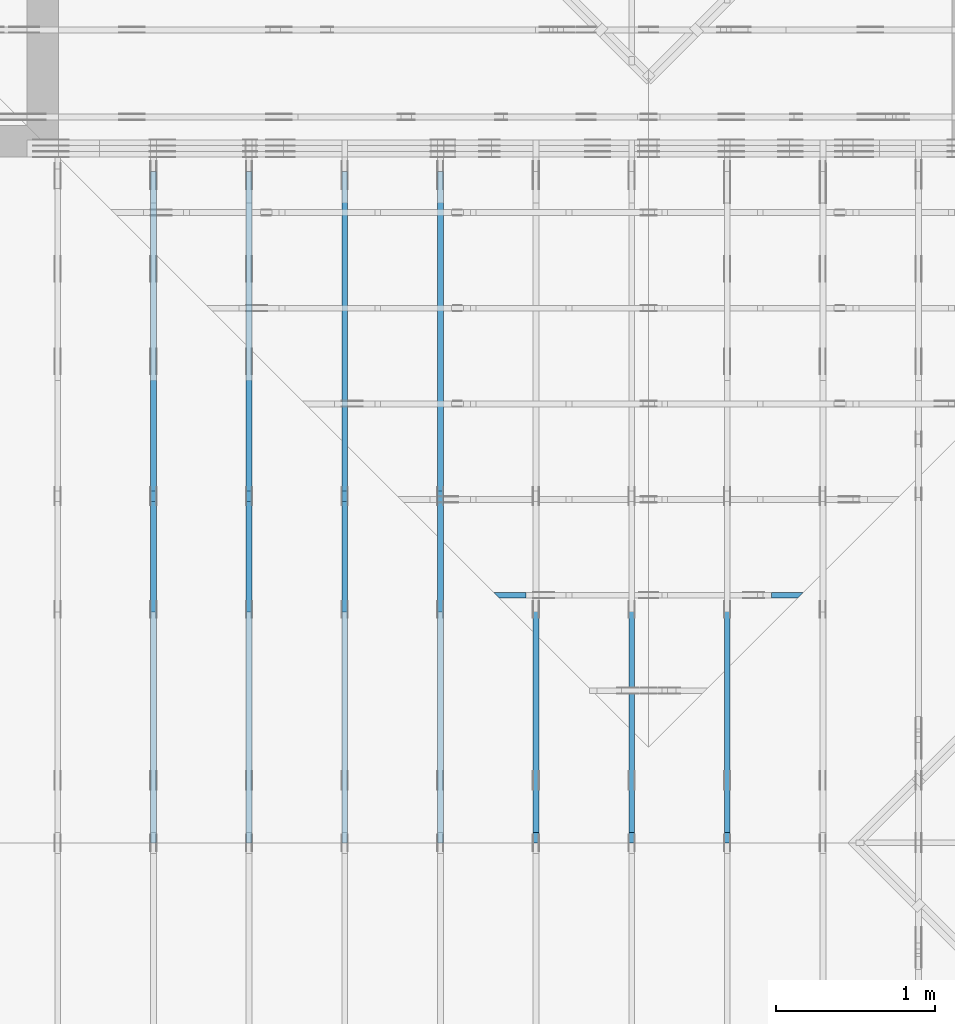
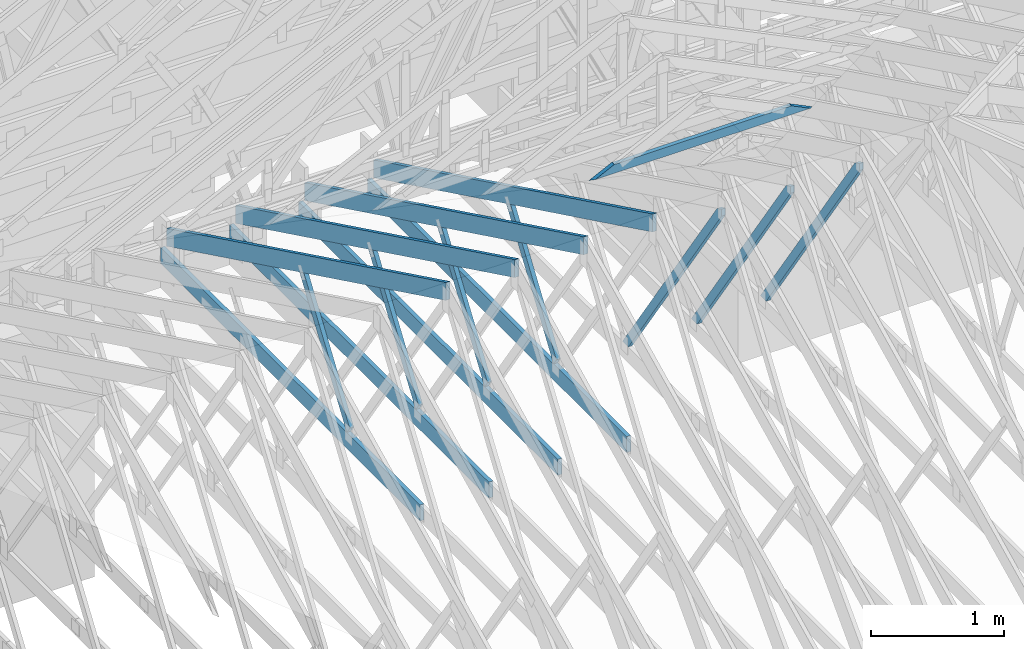
# One storey, part 18 of 159: 16 members, 8 elements without a shape of their own.
"""IFC2X3 building model written with IfcOpenShell, lengths in millimetres."""

from ifc_helpers import new_model, si_unit, frame, origin, origin_with_axes, origin_2d, place, context, project, spatial, faceted_brep, element, aggregate, save


model = new_model("IFC2X3")

# Units and contexts
model_context = context("Model", 3, precision=1e-05, world=origin())
plan_context = context("Plan", 2, precision=1e-05, world=origin_2d())
ifc_project = project(units=[si_unit("LENGTHUNIT", "METRE", prefix="MILLI"), si_unit("AREAUNIT", "SQUARE_METRE"), si_unit("VOLUMEUNIT", "CUBIC_METRE"), si_unit("SOLIDANGLEUNIT", "STERADIAN"), si_unit("PLANEANGLEUNIT", "RADIAN"), si_unit("MASSUNIT", "GRAM"), si_unit("TIMEUNIT", "SECOND"), si_unit("THERMODYNAMICTEMPERATUREUNIT", "DEGREE_CELSIUS"), si_unit("LUMINOUSINTENSITYUNIT", "LUMEN")], contexts=[model_context, plan_context])

# Site, building, storey
site_placement = place(None, origin_with_axes())
site = spatial("IfcSite", under=ifc_project, at=site_placement, CompositionType="ELEMENT")
building_placement = place(site_placement, origin_with_axes())
building = spatial("IfcBuilding", under=site, at=building_placement, Name="Plan 1", CompositionType="ELEMENT")
storey_placement = place(building_placement, origin_with_axes())
storey = spatial("IfcBuildingStorey", under=building, at=storey_placement, Name="Etasje 1", CompositionType="ELEMENT", Elevation=0.0)

# Assembly, member
assembly_1_placement = place(storey_placement, frame((15075.02226140475, -699.9989301294845, 1.1021457184401395e-15), z_axis=(-1.0, 1.836909530733566e-16, 6.123031769111886e-17), x_axis=(-1.836909530733566e-16, -1.0, 0.0)))
assembly_1 = element("IfcElementAssembly", 1, at=assembly_1_placement, inside=storey, Name="T7 (103)", AssemblyPlace="FACTORY", PredefinedType="TRUSS")
member_1_placement = place(assembly_1_placement, frame((-5230.134196319675, 2512.1392759871583, -36.0), z_axis=(0.0, 0.0, 1.0), x_axis=(-0.5642475050074617, -0.8256056886267528, 0.0)))
member_1 = element("IfcMember", 2, at=member_1_placement, Name="T7-D10", context=model_context, shape_type="Brep", body=[
    faceted_brep([(2543.5256108538483, 72.99999048793325, 36.0), (53.406771110820955, 72.99999048793325, 36.0), (0.0, 36.50009322373626, 36.0), (64.12142578860312, 0.00011835360965051223, 36.0), (2593.4163311647717, 0.00011835360965051223, 36.0), (53.406771110820955, 72.99999048793325, 6.5402271239448724e-15), (2543.5256108538483, 72.99999048793325, 3.114817624161566e-13), (2593.4163311647717, 0.00011835360965051223, 3.175914117251098e-13), (64.12142578860312, 0.00011835360965051223, 7.852350543687342e-15), (0.0, 36.50009322373626, 0.0), (3.72532881449672e-05, 36.50017519275116, 3.944304526105059e-31), (3.72532881449672e-05, 36.50017519275116, 36.0), (53.40675570041866, 73.00017519218363, 36.0), (53.40675570041866, 73.00017519218363, 7.888609052210118e-31), (64.12144158709383, 0.00017519218362238576, 7.888609052210118e-31), (64.12144158709383, 0.00017519218362593847, 36.0), (3.7253288159178055e-05, 36.500175192751165, 36.0), (3.72532881574017e-05, 36.500175192751165, -3.944304526105059e-31), (2593.4162114323694, 0.0001751921831566568, 2.916933296842317e-29), (2593.4162114323694, 0.00017519218315886108, 36.0), (64.12144158709384, 0.00017519218362346966, 36.0), (64.12144158709384, 0.00017519218362126537, 7.212035881277958e-31), (2543.52548462057, 73.00017519218363, -8.473528143218631e-30), (2543.52548462057, 73.00017519218363, 36.0), (2593.41621143237, 0.00017519218386041757, 36.0), (2593.41621143237, 0.00017519218386041757, -9.018458054926462e-30), (53.40675570041867, 73.00017519218363, 0.0), (53.40675570041867, 73.00017519218363, 36.0), (2543.52548462057, 73.00017519218348, 36.0), (2543.52548462057, 73.00017519218348, -9.466330862652142e-30)], [[[0, 1, 2, 3, 4]], [[5, 6, 7, 8, 9]], [[10, 11, 12, 13]], [[14, 15, 16, 17]], [[18, 19, 20, 21]], [[22, 23, 24, 25]], [[26, 27, 28, 29]]]),
])
aggregate(assembly_1, [member_1])

assembly_2_placement = place(storey_placement, frame((14475.022261404752, -699.9989301294836, 1.1021457184401395e-15), z_axis=(-1.0, 1.836909530733566e-16, 6.123031769111886e-17), x_axis=(-1.836909530733566e-16, -1.0, 0.0)))
assembly_2 = element("IfcElementAssembly", 3, at=assembly_2_placement, inside=storey, Name="T10 (102)", AssemblyPlace="FACTORY", PredefinedType="TRUSS")
member_2_placement = place(assembly_2_placement, frame((-5230.134196319675, 2512.1392759871583, -36.0), z_axis=(0.0, 0.0, 1.0), x_axis=(-0.5642475050074617, -0.8256056886267528, 0.0)))
member_2 = element("IfcMember", 4, at=member_2_placement, Name="T10-D10", context=model_context, shape_type="Brep", body=[
    faceted_brep([(2543.5256108538483, 72.99999048793325, 36.0), (53.406771110820955, 72.99999048793325, 36.0), (0.0, 36.50009322373626, 36.0), (64.12142578860312, 0.00011835360965051223, 36.0), (2593.4163311647717, 0.00011835360965051223, 36.0), (53.406771110820955, 72.99999048793325, 6.5402271239448724e-15), (2543.5256108538483, 72.99999048793325, 3.114817624161566e-13), (2593.4163311647717, 0.00011835360965051223, 3.175914117251098e-13), (64.12142578860312, 0.00011835360965051223, 7.852350543687342e-15), (0.0, 36.50009322373626, 0.0), (3.72532881449672e-05, 36.50017519275116, 3.944304526105059e-31), (3.72532881449672e-05, 36.50017519275116, 36.0), (53.40675570041866, 73.00017519218363, 36.0), (53.40675570041866, 73.00017519218363, 7.888609052210118e-31), (64.12144158709383, 0.00017519218362238576, 7.888609052210118e-31), (64.12144158709383, 0.00017519218362593847, 36.0), (3.7253288159178055e-05, 36.500175192751165, 36.0), (3.72532881574017e-05, 36.500175192751165, -3.944304526105059e-31), (2593.4162114323694, 0.0001751921831566568, 2.916933296842317e-29), (2593.4162114323694, 0.00017519218315886108, 36.0), (64.12144158709384, 0.00017519218362346966, 36.0), (64.12144158709384, 0.00017519218362126537, 7.212035881277958e-31), (2543.52548462057, 73.00017519218363, -8.473528143218631e-30), (2543.52548462057, 73.00017519218363, 36.0), (2593.41621143237, 0.00017519218386041757, 36.0), (2593.41621143237, 0.00017519218386041757, -9.018458054926462e-30), (53.40675570041867, 73.00017519218363, 0.0), (53.40675570041867, 73.00017519218363, 36.0), (2543.52548462057, 73.00017519218348, 36.0), (2543.52548462057, 73.00017519218348, -9.466330862652142e-30)], [[[0, 1, 2, 3, 4]], [[5, 6, 7, 8, 9]], [[10, 11, 12, 13]], [[14, 15, 16, 17]], [[18, 19, 20, 21]], [[22, 23, 24, 25]], [[26, 27, 28, 29]]]),
])
aggregate(assembly_2, [member_2])

assembly_3_placement = place(storey_placement, frame((13875.022261404752, -699.9989301294836, 1.1021457184401395e-15), z_axis=(-1.0, 1.836909530733566e-16, 6.123031769111886e-17), x_axis=(-1.836909530733566e-16, -1.0, 0.0)))
assembly_3 = element("IfcElementAssembly", 5, at=assembly_3_placement, inside=storey, Name="T6 (101)", AssemblyPlace="FACTORY", PredefinedType="TRUSS")
member_3_placement = place(assembly_3_placement, frame((-5230.134196319675, 2512.1392759871583, -36.0), z_axis=(0.0, 0.0, 1.0), x_axis=(-0.5642475050074617, -0.8256056886267528, 0.0)))
member_3 = element("IfcMember", 6, at=member_3_placement, Name="T6-D10", context=model_context, shape_type="Brep", body=[
    faceted_brep([(2543.5256108538483, 72.99999048793325, 36.0), (53.406771110820955, 72.99999048793325, 36.0), (0.0, 36.50009322373626, 36.0), (64.12142578860312, 0.00011835360965051223, 36.0), (2593.4163311647717, 0.00011835360965051223, 36.0), (53.406771110820955, 72.99999048793325, 6.5402271239448724e-15), (2543.5256108538483, 72.99999048793325, 3.114817624161566e-13), (2593.4163311647717, 0.00011835360965051223, 3.175914117251098e-13), (64.12142578860312, 0.00011835360965051223, 7.852350543687342e-15), (0.0, 36.50009322373626, 0.0), (3.72532881449672e-05, 36.50017519275116, 3.944304526105059e-31), (3.72532881449672e-05, 36.50017519275116, 36.0), (53.40675570041866, 73.00017519218363, 36.0), (53.40675570041866, 73.00017519218363, 7.888609052210118e-31), (64.12144158709383, 0.00017519218362238576, 7.888609052210118e-31), (64.12144158709383, 0.00017519218362593847, 36.0), (3.7253288159178055e-05, 36.500175192751165, 36.0), (3.72532881574017e-05, 36.500175192751165, -3.944304526105059e-31), (2593.4162114323694, 0.0001751921831566568, 2.916933296842317e-29), (2593.4162114323694, 0.00017519218315886108, 36.0), (64.12144158709384, 0.00017519218362346966, 36.0), (64.12144158709384, 0.00017519218362126537, 7.212035881277958e-31), (2543.52548462057, 73.00017519218363, -8.473528143218631e-30), (2543.52548462057, 73.00017519218363, 36.0), (2593.41621143237, 0.00017519218386041757, 36.0), (2593.41621143237, 0.00017519218386041757, -9.018458054926462e-30), (53.40675570041867, 73.00017519218363, 0.0), (53.40675570041867, 73.00017519218363, 36.0), (2543.52548462057, 73.00017519218348, 36.0), (2543.52548462057, 73.00017519218348, -9.466330862652142e-30)], [[[0, 1, 2, 3, 4]], [[5, 6, 7, 8, 9]], [[10, 11, 12, 13]], [[14, 15, 16, 17]], [[18, 19, 20, 21]], [[22, 23, 24, 25]], [[26, 27, 28, 29]]]),
])
aggregate(assembly_3, [member_3])

# Assembly, members
assembly_4_placement = place(storey_placement, frame((13275.022261404752, -699.9989301294836, 1.1021457184401395e-15), z_axis=(-1.0, 1.836909530733566e-16, 6.123031769111886e-17), x_axis=(-1.836909530733566e-16, -1.0, 0.0)))
assembly_4 = element("IfcElementAssembly", 7, at=assembly_4_placement, inside=storey, Name="T6 (100)", AssemblyPlace="FACTORY", PredefinedType="TRUSS")
member_4_placement = place(assembly_4_placement, frame((-9411.999005287185, 437.2146234308699, -36.00000000000001), z_axis=(0.0, 0.0, 1.0), x_axis=(0.8987940462991673, 0.43837114678907735, 0.0)))
member_4 = element("IfcMember", 8, at=member_4_placement, Name="T6-O11", context=model_context, shape_type="Brep", body=[
    faceted_brep([(4758.463277584195, 148.00009154954296, 36.0), (72.18442876594781, 148.00009154954296, 36.0), (0.0, 4.140399232710479e-05, 36.0), (4686.278875574299, 4.140399232710479e-05, 36.0), (72.18442876594781, 148.00009154954296, 8.839751011381847e-15), (4758.463277584195, 148.00009154954296, 5.82724436416006e-13), (4686.278875574299, 4.140399232710479e-05, 5.738846886811872e-13), (0.0, 4.140399232710479e-05, 0.0), (8.360351420234293e-05, 5.140324472498181e-15, 7.179836740020234e-31), (8.360351420432413e-05, 4.174029286270475e-15, 36.0), (72.18450667705471, 147.99999999603824, 36.0), (72.18450667705471, 147.99999999603824, 1.530729119798975e-30), (4686.27888374885, 4.514103814251943e-05, -1.8242490005659002e-29), (4686.27888374885, 4.514103814472372e-05, 36.0), (8.360351421288216e-05, 2.204296752011599e-15, 36.0), (8.360351421288216e-05, 5.315131319929112e-21, -3.254471682622608e-37), (4758.463306857064, 148.00004514198963, 1.58299098763632e-28), (4758.463306857064, 148.00004514198963, 36.0), (4686.2788837488515, 4.5141036935092416e-05, 36.0), (4686.2788837488515, 4.5141036935092416e-05, 1.0730458735393999e-28), (72.18450667705474, 147.99999999603824, 0.0), (72.18450667705474, 147.99999999603824, 36.0), (4758.463306857063, 148.00004514199048, 36.0), (4758.463306857063, 148.00004514199048, -2.8398992587956425e-29)], [[[0, 1, 2, 3]], [[4, 5, 6, 7]], [[8, 9, 10, 11]], [[12, 13, 14, 15]], [[16, 17, 18, 19]], [[20, 21, 22, 23]]]),
])
member_5_placement = place(assembly_4_placement, frame((-5591.18115234375, 371.0, -36.0), z_axis=(0.0, 0.0, 1.0), x_axis=(-1.0, 1.2246063538223773e-16, 0.0)))
member_5 = element("IfcMember", 9, at=member_5_placement, Name="T6-U39", context=model_context, shape_type="Brep", body=[
    faceted_brep([(3910.81787109375, 148.00000000000048, 36.0), (0.0, 148.00000000000048, 36.0), (0.0, 0.0, 36.0), (3910.81787109375, 0.0, 36.0), (0.0, 148.00000000000048, 0.0), (3910.81787109375, 148.00000000000048, 4.789212413583509e-13), (3910.81787109375, 0.0, 4.789212413583509e-13), (0.0, 0.0, 0.0), (0.0001433398574590683, 3.979039320256561e-13, 0.0), (0.0001433398574612726, 3.979039320256561e-13, 36.0), (0.00014333985747939676, 148.00000000000037, 36.0), (0.00014333985747719247, 148.00000000000037, -1.1097494219785373e-30), (3910.817777776101, -3.204779149536956e-13, 4.746728930957506e-29), (3910.817777776101, -3.182736235168153e-13, 36.0), (0.0001433398574590683, 4.001081950488681e-13, 36.0), (0.0001433398574590683, 3.9790390361198783e-13, 1.73977793531565e-36), (3910.817777776101, 148.00000000000048, 0.0), (3910.817777776101, 148.00000000000048, 36.0), (3910.817777776101, 4.547473508864641e-13, 36.0), (3910.817777776101, 4.547473508864641e-13, 0.0), (0.0001433398574590683, 148.00000000000037, 0.0), (0.0001433398574590683, 148.00000000000037, 36.0), (3910.817777776101, 148.0000000000001, 36.0), (3910.817777776101, 148.00000000000014, -2.208810534618833e-29)], [[[0, 1, 2, 3]], [[4, 5, 6, 7]], [[8, 9, 10, 11]], [[12, 13, 14, 15]], [[16, 17, 18, 19]], [[20, 21, 22, 23]]]),
])
member_6_placement = place(assembly_4_placement, frame((-7407.03695472166, 1415.0999762480442, -36.0), z_axis=(0.0, 0.0, 1.0), x_axis=(0.5642475050064201, -0.8256056886274645, 0.0)))
member_6 = element("IfcMember", 10, at=member_6_placement, Name="T6-D42", context=model_context, shape_type="Brep", body=[
    faceted_brep([(1236.1859046255386, 72.99999679664234, 36.0), (10.714742691100582, 72.99999679664234, 36.0), (8.80134111866937e-05, 0.0003439493775658775, 36.0), (1264.647265190018, 0.0003439493775658775, 36.0), (10.714742691100582, 72.99999679664234, 1.312134197909365e-15), (1236.1859046255386, 72.99999679664234, 1.5138411133100978e-13), (1264.647265190018, 0.0003439493775658775, 1.548695076295789e-13), (8.80134111866937e-05, 0.0003439493775658775, 1.077817825608066e-20), (1.2441219929271163e-16, 0.00017519218454252033, -7.699393958337917e-33), (2.305335691224139e-15, 0.00017519218454220022, 36.0), (10.714685884795475, 73.00017519218454, 36.0), (10.714685884795474, 73.00017519218454, -2.956283656724794e-32), (1264.6473849224226, 0.00017519218655669935, 4.373824669985916e-29), (1264.6473849224226, 0.00017519218655890365, 36.0), (-3.510681399126273e-30, 0.0001751921845447429, 36.0), (0.0, 0.0001751921845425386, 0.0), (1236.1860298802894, 73.00017519218727, -1.3795914725131465e-29), (1236.1860298802894, 73.00017519218727, 36.0), (1264.6473849224226, 0.0001751921872710227, 36.0), (1264.6473849224226, 0.0001751921872710227, -1.4037355718167356e-29), (10.714685884795474, 73.00017519218454, 0.0), (10.714685884795474, 73.00017519218453, 36.0), (1236.1860298802894, 73.00017519218719, 36.0), (1236.1860298802894, 73.00017519218719, -5.5220263365470826e-30)], [[[0, 1, 2, 3]], [[4, 5, 6, 7]], [[8, 9, 10, 11]], [[12, 13, 14, 15]], [[16, 17, 18, 19]], [[20, 21, 22, 23]]]),
])
aggregate(assembly_4, [member_4, member_5, member_6])

assembly_5_placement = place(storey_placement, frame((12675.022261404752, -699.9989301294854, 4.558494966049043e-13), z_axis=(-1.0, 1.836909530733566e-16, 6.123031769111886e-17), x_axis=(-1.836909530733566e-16, -1.0, 0.0)))
assembly_5 = element("IfcElementAssembly", 11, at=assembly_5_placement, inside=storey, Name="T6 (99)", AssemblyPlace="FACTORY", PredefinedType="TRUSS")
member_7_placement = place(assembly_5_placement, frame((-9411.999005287185, 437.2146234308699, -36.00000000000001), z_axis=(0.0, 0.0, 1.0), x_axis=(0.8987940462991673, 0.43837114678907735, 0.0)))
member_7 = element("IfcMember", 12, at=member_7_placement, Name="T6-O11", context=model_context, shape_type="Brep", body=[
    faceted_brep([(4758.463277584195, 148.00009154954296, 36.0), (72.18442876594781, 148.00009154954296, 36.0), (0.0, 4.140399232710479e-05, 36.0), (4686.278875574299, 4.140399232710479e-05, 36.0), (72.18442876594781, 148.00009154954296, 8.839751011381847e-15), (4758.463277584195, 148.00009154954296, 5.82724436416006e-13), (4686.278875574299, 4.140399232710479e-05, 5.738846886811872e-13), (0.0, 4.140399232710479e-05, 0.0), (8.360351420234293e-05, 5.140324472498181e-15, 7.179836740020234e-31), (8.360351420432413e-05, 4.174029286270475e-15, 36.0), (72.18450667705471, 147.99999999603824, 36.0), (72.18450667705471, 147.99999999603824, 1.530729119798975e-30), (4686.27888374885, 4.514103814251943e-05, -1.8242490005659002e-29), (4686.27888374885, 4.514103814472372e-05, 36.0), (8.360351421288216e-05, 2.204296752011599e-15, 36.0), (8.360351421288216e-05, 5.315131319929112e-21, -3.254471682622608e-37), (4758.463306857064, 148.00004514198963, 1.58299098763632e-28), (4758.463306857064, 148.00004514198963, 36.0), (4686.2788837488515, 4.5141036935092416e-05, 36.0), (4686.2788837488515, 4.5141036935092416e-05, 1.0730458735393999e-28), (72.18450667705474, 147.99999999603824, 0.0), (72.18450667705474, 147.99999999603824, 36.0), (4758.463306857063, 148.00004514199048, 36.0), (4758.463306857063, 148.00004514199048, -2.8398992587956425e-29)], [[[0, 1, 2, 3]], [[4, 5, 6, 7]], [[8, 9, 10, 11]], [[12, 13, 14, 15]], [[16, 17, 18, 19]], [[20, 21, 22, 23]]]),
])
member_8_placement = place(assembly_5_placement, frame((-5591.18115234375, 371.0, -36.0), z_axis=(0.0, 0.0, 1.0), x_axis=(-1.0, 1.2246063538223773e-16, 0.0)))
member_8 = element("IfcMember", 13, at=member_8_placement, Name="T6-U39", context=model_context, shape_type="Brep", body=[
    faceted_brep([(3910.81787109375, 148.00000000000048, 36.0), (0.0, 148.00000000000048, 36.0), (0.0, 0.0, 36.0), (3910.81787109375, 0.0, 36.0), (0.0, 148.00000000000048, 0.0), (3910.81787109375, 148.00000000000048, 4.789212413583509e-13), (3910.81787109375, 0.0, 4.789212413583509e-13), (0.0, 0.0, 0.0), (0.0001433398574590683, 3.979039320256561e-13, 0.0), (0.0001433398574612726, 3.979039320256561e-13, 36.0), (0.00014333985747939676, 148.00000000000037, 36.0), (0.00014333985747719247, 148.00000000000037, -1.1097494219785373e-30), (3910.817777776101, -3.204779149536956e-13, 4.746728930957506e-29), (3910.817777776101, -3.182736235168153e-13, 36.0), (0.0001433398574590683, 4.001081950488681e-13, 36.0), (0.0001433398574590683, 3.9790390361198783e-13, 1.73977793531565e-36), (3910.817777776101, 148.00000000000048, 0.0), (3910.817777776101, 148.00000000000048, 36.0), (3910.817777776101, 4.547473508864641e-13, 36.0), (3910.817777776101, 4.547473508864641e-13, 0.0), (0.0001433398574590683, 148.00000000000037, 0.0), (0.0001433398574590683, 148.00000000000037, 36.0), (3910.817777776101, 148.0000000000001, 36.0), (3910.817777776101, 148.00000000000014, -2.208810534618833e-29)], [[[0, 1, 2, 3]], [[4, 5, 6, 7]], [[8, 9, 10, 11]], [[12, 13, 14, 15]], [[16, 17, 18, 19]], [[20, 21, 22, 23]]]),
])
member_9_placement = place(assembly_5_placement, frame((-7407.03695472166, 1415.0999762480442, -36.0), z_axis=(0.0, 0.0, 1.0), x_axis=(0.5642475050064201, -0.8256056886274645, 0.0)))
member_9 = element("IfcMember", 14, at=member_9_placement, Name="T6-D42", context=model_context, shape_type="Brep", body=[
    faceted_brep([(1236.1859046255386, 72.99999679664234, 36.0), (10.714742691100582, 72.99999679664234, 36.0), (8.80134111866937e-05, 0.0003439493775658775, 36.0), (1264.647265190018, 0.0003439493775658775, 36.0), (10.714742691100582, 72.99999679664234, 1.312134197909365e-15), (1236.1859046255386, 72.99999679664234, 1.5138411133100978e-13), (1264.647265190018, 0.0003439493775658775, 1.548695076295789e-13), (8.80134111866937e-05, 0.0003439493775658775, 1.077817825608066e-20), (1.2441219929271163e-16, 0.00017519218454252033, -7.699393958337917e-33), (2.305335691224139e-15, 0.00017519218454220022, 36.0), (10.714685884795475, 73.00017519218454, 36.0), (10.714685884795474, 73.00017519218454, -2.956283656724794e-32), (1264.6473849224226, 0.00017519218655669935, 4.373824669985916e-29), (1264.6473849224226, 0.00017519218655890365, 36.0), (-3.510681399126273e-30, 0.0001751921845447429, 36.0), (0.0, 0.0001751921845425386, 0.0), (1236.1860298802894, 73.00017519218727, -1.3795914725131465e-29), (1236.1860298802894, 73.00017519218727, 36.0), (1264.6473849224226, 0.0001751921872710227, 36.0), (1264.6473849224226, 0.0001751921872710227, -1.4037355718167356e-29), (10.714685884795474, 73.00017519218454, 0.0), (10.714685884795474, 73.00017519218453, 36.0), (1236.1860298802894, 73.00017519218719, 36.0), (1236.1860298802894, 73.00017519218719, -5.5220263365470826e-30)], [[[0, 1, 2, 3]], [[4, 5, 6, 7]], [[8, 9, 10, 11]], [[12, 13, 14, 15]], [[16, 17, 18, 19]], [[20, 21, 22, 23]]]),
])
aggregate(assembly_5, [member_7, member_8, member_9])

assembly_6_placement = place(storey_placement, frame((12075.022261404752, -699.9989301294854, 4.558494966049043e-13), z_axis=(-1.0, 1.836909530733566e-16, 6.123031769111886e-17), x_axis=(-1.836909530733566e-16, -1.0, 0.0)))
assembly_6 = element("IfcElementAssembly", 15, at=assembly_6_placement, inside=storey, Name="T5 (98)", AssemblyPlace="FACTORY", PredefinedType="TRUSS")
member_10_placement = place(assembly_6_placement, frame((-9411.999005287185, 437.2146234308699, -36.00000000000001), z_axis=(0.0, 0.0, 1.0), x_axis=(0.8987940462991673, 0.43837114678907735, 0.0)))
member_10 = element("IfcMember", 16, at=member_10_placement, Name="T5-O11", context=model_context, shape_type="Brep", body=[
    faceted_brep([(4758.463277584195, 148.00009154954296, 36.0), (72.18442876594781, 148.00009154954296, 36.0), (0.0, 4.140399232710479e-05, 36.0), (4686.278875574299, 4.140399232710479e-05, 36.0), (72.18442876594781, 148.00009154954296, 8.839751011381847e-15), (4758.463277584195, 148.00009154954296, 5.82724436416006e-13), (4686.278875574299, 4.140399232710479e-05, 5.738846886811872e-13), (0.0, 4.140399232710479e-05, 0.0), (8.360351420234293e-05, 5.140324472498181e-15, 7.179836740020234e-31), (8.360351420432413e-05, 4.174029286270475e-15, 36.0), (72.18450667705471, 147.99999999603824, 36.0), (72.18450667705471, 147.99999999603824, 1.530729119798975e-30), (4686.27888374885, 4.514103814251943e-05, -1.8242490005659002e-29), (4686.27888374885, 4.514103814472372e-05, 36.0), (8.360351421288216e-05, 2.204296752011599e-15, 36.0), (8.360351421288216e-05, 5.315131319929112e-21, -3.254471682622608e-37), (4758.463306857064, 148.00004514198963, 1.58299098763632e-28), (4758.463306857064, 148.00004514198963, 36.0), (4686.2788837488515, 4.5141036935092416e-05, 36.0), (4686.2788837488515, 4.5141036935092416e-05, 1.0730458735393999e-28), (72.18450667705474, 147.99999999603824, 0.0), (72.18450667705474, 147.99999999603824, 36.0), (4758.463306857063, 148.00004514199048, 36.0), (4758.463306857063, 148.00004514199048, -2.8398992587956425e-29)], [[[0, 1, 2, 3]], [[4, 5, 6, 7]], [[8, 9, 10, 11]], [[12, 13, 14, 15]], [[16, 17, 18, 19]], [[20, 21, 22, 23]]]),
])
member_11_placement = place(assembly_6_placement, frame((-5591.18115234375, 371.0, -36.0), z_axis=(0.0, 0.0, 1.0), x_axis=(-1.0, 1.2246063538223773e-16, 0.0)))
member_11 = element("IfcMember", 17, at=member_11_placement, Name="T5-U39", context=model_context, shape_type="Brep", body=[
    faceted_brep([(3910.81787109375, 148.00000000000048, 36.0), (0.0, 148.00000000000048, 36.0), (0.0, 0.0, 36.0), (3910.81787109375, 0.0, 36.0), (0.0, 148.00000000000048, 0.0), (3910.81787109375, 148.00000000000048, 4.789212413583509e-13), (3910.81787109375, 0.0, 4.789212413583509e-13), (0.0, 0.0, 0.0), (0.0001433398574590683, 3.979039320256561e-13, 0.0), (0.0001433398574612726, 3.979039320256561e-13, 36.0), (0.00014333985747939676, 148.00000000000037, 36.0), (0.00014333985747719247, 148.00000000000037, -1.1097494219785373e-30), (3910.817777776101, -3.204779149536956e-13, 4.746728930957506e-29), (3910.817777776101, -3.182736235168153e-13, 36.0), (0.0001433398574590683, 4.001081950488681e-13, 36.0), (0.0001433398574590683, 3.9790390361198783e-13, 1.73977793531565e-36), (3910.817777776101, 148.00000000000048, 0.0), (3910.817777776101, 148.00000000000048, 36.0), (3910.817777776101, 4.547473508864641e-13, 36.0), (3910.817777776101, 4.547473508864641e-13, 0.0), (0.0001433398574590683, 148.00000000000037, 0.0), (0.0001433398574590683, 148.00000000000037, 36.0), (3910.817777776101, 148.0000000000001, 36.0), (3910.817777776101, 148.00000000000014, -2.208810534618833e-29)], [[[0, 1, 2, 3]], [[4, 5, 6, 7]], [[8, 9, 10, 11]], [[12, 13, 14, 15]], [[16, 17, 18, 19]], [[20, 21, 22, 23]]]),
])
member_12_placement = place(assembly_6_placement, frame((-7407.03695472166, 1415.0999762480442, -36.0), z_axis=(0.0, 0.0, 1.0), x_axis=(0.5642475050064201, -0.8256056886274645, 0.0)))
member_12 = element("IfcMember", 18, at=member_12_placement, Name="T5-D42", context=model_context, shape_type="Brep", body=[
    faceted_brep([(1236.1859046255386, 72.99999679664234, 36.0), (10.714742691100582, 72.99999679664234, 36.0), (8.80134111866937e-05, 0.0003439493775658775, 36.0), (1264.647265190018, 0.0003439493775658775, 36.0), (10.714742691100582, 72.99999679664234, 1.312134197909365e-15), (1236.1859046255386, 72.99999679664234, 1.5138411133100978e-13), (1264.647265190018, 0.0003439493775658775, 1.548695076295789e-13), (8.80134111866937e-05, 0.0003439493775658775, 1.077817825608066e-20), (1.2441219929271163e-16, 0.00017519218454252033, -7.699393958337917e-33), (2.305335691224139e-15, 0.00017519218454220022, 36.0), (10.714685884795475, 73.00017519218454, 36.0), (10.714685884795474, 73.00017519218454, -2.956283656724794e-32), (1264.6473849224226, 0.00017519218655669935, 4.373824669985916e-29), (1264.6473849224226, 0.00017519218655890365, 36.0), (-3.510681399126273e-30, 0.0001751921845447429, 36.0), (0.0, 0.0001751921845425386, 0.0), (1236.1860298802894, 73.00017519218727, -1.3795914725131465e-29), (1236.1860298802894, 73.00017519218727, 36.0), (1264.6473849224226, 0.0001751921872710227, 36.0), (1264.6473849224226, 0.0001751921872710227, -1.4037355718167356e-29), (10.714685884795474, 73.00017519218454, 0.0), (10.714685884795474, 73.00017519218453, 36.0), (1236.1860298802894, 73.00017519218719, 36.0), (1236.1860298802894, 73.00017519218719, -5.5220263365470826e-30)], [[[0, 1, 2, 3]], [[4, 5, 6, 7]], [[8, 9, 10, 11]], [[12, 13, 14, 15]], [[16, 17, 18, 19]], [[20, 21, 22, 23]]]),
])
aggregate(assembly_6, [member_10, member_11, member_12])

assembly_7_placement = place(storey_placement, frame((11475.022261404752, -699.9989301294845, 1.1021457184401395e-15), z_axis=(-1.0, 1.836909530733566e-16, 6.123031769111886e-17), x_axis=(-1.836909530733566e-16, -1.0, 0.0)))
assembly_7 = element("IfcElementAssembly", 19, at=assembly_7_placement, inside=storey, Name="T5 (97)", AssemblyPlace="FACTORY", PredefinedType="TRUSS")
member_13_placement = place(assembly_7_placement, frame((-9411.999005287185, 437.2146234308699, -36.00000000000001), z_axis=(0.0, 0.0, 1.0), x_axis=(0.8987940462991673, 0.43837114678907735, 0.0)))
member_13 = element("IfcMember", 20, at=member_13_placement, Name="T5-O11", context=model_context, shape_type="Brep", body=[
    faceted_brep([(4758.463277584195, 148.00009154954296, 36.0), (72.18442876594781, 148.00009154954296, 36.0), (0.0, 4.140399232710479e-05, 36.0), (4686.278875574299, 4.140399232710479e-05, 36.0), (72.18442876594781, 148.00009154954296, 8.839751011381847e-15), (4758.463277584195, 148.00009154954296, 5.82724436416006e-13), (4686.278875574299, 4.140399232710479e-05, 5.738846886811872e-13), (0.0, 4.140399232710479e-05, 0.0), (8.360351420234293e-05, 5.140324472498181e-15, 7.179836740020234e-31), (8.360351420432413e-05, 4.174029286270475e-15, 36.0), (72.18450667705471, 147.99999999603824, 36.0), (72.18450667705471, 147.99999999603824, 1.530729119798975e-30), (4686.27888374885, 4.514103814251943e-05, -1.8242490005659002e-29), (4686.27888374885, 4.514103814472372e-05, 36.0), (8.360351421288216e-05, 2.204296752011599e-15, 36.0), (8.360351421288216e-05, 5.315131319929112e-21, -3.254471682622608e-37), (4758.463306857064, 148.00004514198963, 1.58299098763632e-28), (4758.463306857064, 148.00004514198963, 36.0), (4686.2788837488515, 4.5141036935092416e-05, 36.0), (4686.2788837488515, 4.5141036935092416e-05, 1.0730458735393999e-28), (72.18450667705474, 147.99999999603824, 0.0), (72.18450667705474, 147.99999999603824, 36.0), (4758.463306857063, 148.00004514199048, 36.0), (4758.463306857063, 148.00004514199048, -2.8398992587956425e-29)], [[[0, 1, 2, 3]], [[4, 5, 6, 7]], [[8, 9, 10, 11]], [[12, 13, 14, 15]], [[16, 17, 18, 19]], [[20, 21, 22, 23]]]),
])
member_14_placement = place(assembly_7_placement, frame((-5591.18115234375, 371.0, -36.0), z_axis=(0.0, 0.0, 1.0), x_axis=(-1.0, 1.2246063538223773e-16, 0.0)))
member_14 = element("IfcMember", 21, at=member_14_placement, Name="T5-U39", context=model_context, shape_type="Brep", body=[
    faceted_brep([(3910.81787109375, 148.00000000000048, 36.0), (0.0, 148.00000000000048, 36.0), (0.0, 0.0, 36.0), (3910.81787109375, 0.0, 36.0), (0.0, 148.00000000000048, 0.0), (3910.81787109375, 148.00000000000048, 4.789212413583509e-13), (3910.81787109375, 0.0, 4.789212413583509e-13), (0.0, 0.0, 0.0), (0.0001433398574590683, 3.979039320256561e-13, 0.0), (0.0001433398574612726, 3.979039320256561e-13, 36.0), (0.00014333985747939676, 148.00000000000037, 36.0), (0.00014333985747719247, 148.00000000000037, -1.1097494219785373e-30), (3910.817777776101, -3.204779149536956e-13, 4.746728930957506e-29), (3910.817777776101, -3.182736235168153e-13, 36.0), (0.0001433398574590683, 4.001081950488681e-13, 36.0), (0.0001433398574590683, 3.9790390361198783e-13, 1.73977793531565e-36), (3910.817777776101, 148.00000000000048, 0.0), (3910.817777776101, 148.00000000000048, 36.0), (3910.817777776101, 4.547473508864641e-13, 36.0), (3910.817777776101, 4.547473508864641e-13, 0.0), (0.0001433398574590683, 148.00000000000037, 0.0), (0.0001433398574590683, 148.00000000000037, 36.0), (3910.817777776101, 148.0000000000001, 36.0), (3910.817777776101, 148.00000000000014, -2.208810534618833e-29)], [[[0, 1, 2, 3]], [[4, 5, 6, 7]], [[8, 9, 10, 11]], [[12, 13, 14, 15]], [[16, 17, 18, 19]], [[20, 21, 22, 23]]]),
])
member_15_placement = place(assembly_7_placement, frame((-7407.03695472166, 1415.0999762480442, -36.0), z_axis=(0.0, 0.0, 1.0), x_axis=(0.5642475050064201, -0.8256056886274645, 0.0)))
member_15 = element("IfcMember", 22, at=member_15_placement, Name="T5-D42", context=model_context, shape_type="Brep", body=[
    faceted_brep([(1236.1859046255386, 72.99999679664234, 36.0), (10.714742691100582, 72.99999679664234, 36.0), (8.80134111866937e-05, 0.0003439493775658775, 36.0), (1264.647265190018, 0.0003439493775658775, 36.0), (10.714742691100582, 72.99999679664234, 1.312134197909365e-15), (1236.1859046255386, 72.99999679664234, 1.5138411133100978e-13), (1264.647265190018, 0.0003439493775658775, 1.548695076295789e-13), (8.80134111866937e-05, 0.0003439493775658775, 1.077817825608066e-20), (1.2441219929271163e-16, 0.00017519218454252033, -7.699393958337917e-33), (2.305335691224139e-15, 0.00017519218454220022, 36.0), (10.714685884795475, 73.00017519218454, 36.0), (10.714685884795474, 73.00017519218454, -2.956283656724794e-32), (1264.6473849224226, 0.00017519218655669935, 4.373824669985916e-29), (1264.6473849224226, 0.00017519218655890365, 36.0), (-3.510681399126273e-30, 0.0001751921845447429, 36.0), (0.0, 0.0001751921845425386, 0.0), (1236.1860298802894, 73.00017519218727, -1.3795914725131465e-29), (1236.1860298802894, 73.00017519218727, 36.0), (1264.6473849224226, 0.0001751921872710227, 36.0), (1264.6473849224226, 0.0001751921872710227, -1.4037355718167356e-29), (10.714685884795474, 73.00017519218454, 0.0), (10.714685884795474, 73.00017519218453, 36.0), (1236.1860298802894, 73.00017519218719, 36.0), (1236.1860298802894, 73.00017519218719, -5.5220263365470826e-30)], [[[0, 1, 2, 3]], [[4, 5, 6, 7]], [[8, 9, 10, 11]], [[12, 13, 14, 15]], [[16, 17, 18, 19]], [[20, 21, 22, 23]]]),
])
aggregate(assembly_7, [member_13, member_14, member_15])

# Assembly, member
assembly_8_placement = place(storey_placement, frame((13646.012618823253, 6036.0000442782275, 1898.2729963151946), z_axis=(0.0, -1.0, 6.123031769111886e-17), x_axis=(1.0, 0.0, 0.0)))
assembly_8 = element("IfcElementAssembly", 23, at=assembly_8_placement, inside=storey, Name="Tr5 (109)", AssemblyPlace="FACTORY", PredefinedType="TRUSS")
member_16_placement = place(assembly_8_placement, frame((1926.0000569065835, 89.22082935512393, -36.00000000000043), z_axis=(0.0, 0.0, 1.0), x_axis=(-1.0, 1.2246063538223773e-16, 0.0)))
member_16 = element("IfcMember", 24, at=member_16_placement, Name="Tr5-U47", context=model_context, shape_type="Brep", body=[
    faceted_brep([(2.4872812218745818e-05, 98.00000032462525, 3.203594326350867e-05), (36.00002487281222, 80.4416425728618, 36.0000003862133), (1908.0000553903903, 80.4416425728617, 36.00000038621326), (1944.0000248728122, 98.00000032462519, 3.203594312850555e-05), (1908.0000569087497, 80.44164276123048, 36.00000000000043), (35.999934838437184, 80.44164276123048, 36.00000000000043), (200.92974440874968, 0.0, 36.00000000000043), (1743.0702473384372, 0.0, 36.00000000000043), (200.92977300652683, 2.203832906388925e-06, 3.1263880373444403e-13), (200.92977300652683, 2.2038328921780703e-06, 36.00000000000043), (35.99996835020807, 80.4416427612302, 36.00000000000043), (7.105427357601002e-15, 98.00000051312105, 3.051757858685277e-05), (1743.0702483979787, 3.2462495580740444e-07, 4.334310688136611e-13), (1743.0702483979787, 3.246249580116959e-07, 36.00000000000043), (200.92974546829123, 3.2462524128895466e-07, 36.00000000000043), (200.92974546829123, 3.246252390846632e-07, 4.334310688136611e-13), (1944.0000248728115, 98.00000032462606, 3.2035943171138115e-05), (1908.0000565225405, 80.44164257286468, 36.000001518365046), (1743.0702518659327, 2.0160603071417427e-06, 36.000001518365025), (1743.0702518659327, 2.0160603071417427e-06, -8.077935669463161e-28), (2.487281221874582e-05, 98.00000032462506, 4.334310718596015e-13), (1944.0000248728122, 98.00000032462506, 6.714945470426716e-13), (1743.0702458200778, 3.246253044153491e-07, 6.468885586326611e-13), (200.92983444312472, 3.246253044153491e-07, 4.580370640068139e-13)], [[[0, 1, 2, 3]], [[4, 5, 6, 7]], [[8, 9, 10, 11]], [[12, 13, 14, 15]], [[16, 17, 18, 19]], [[20, 21, 22, 23]]]),
])
aggregate(assembly_8, [member_16])

save(model, "model.ifc")
